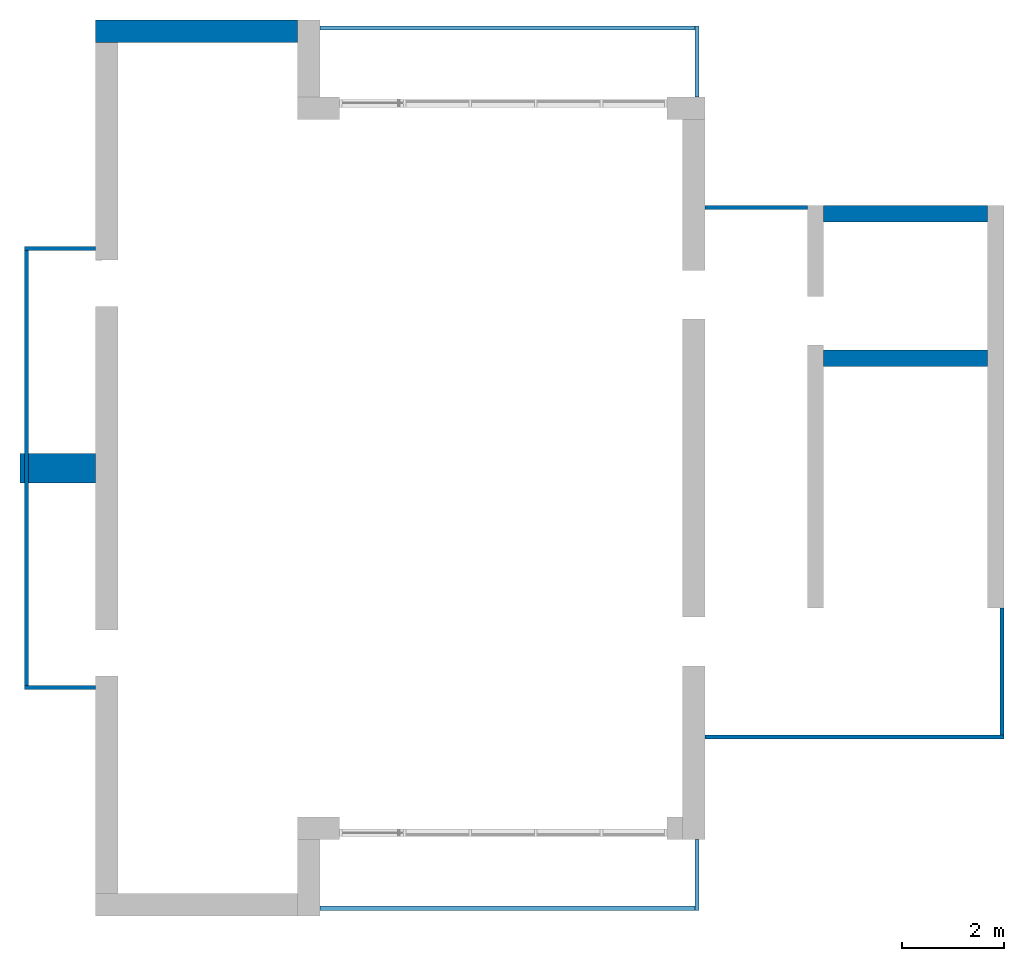
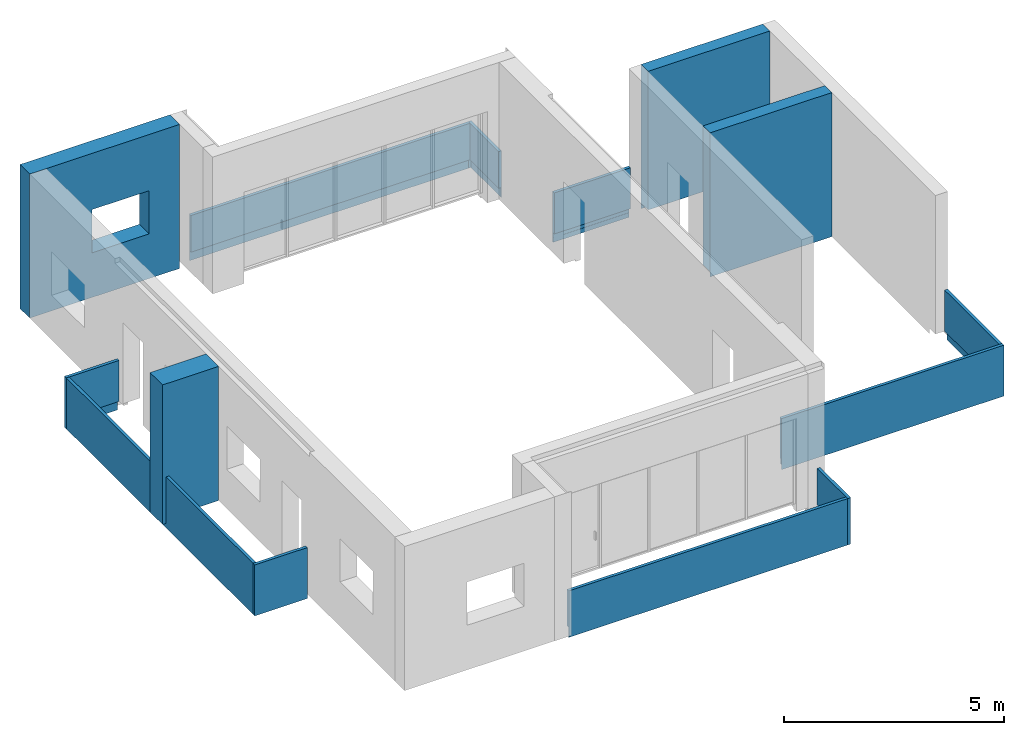
# One storey, part 2 of 4: 14 walls, 1 opening.
"""IFC2X3 building model written with IfcOpenShell, lengths in millimetres."""

from ifc_helpers import new_model, entity, si_unit, converted_unit, derived_unit, direction, frame, frame_2d, origin, place, context, subcontext, project, spatial, polyline, rectangle, extrude, clip, bounded_halfspace, faceted_brep, material, layer, layer_set, layer_usage, type_object, element, save


model = new_model("IFC2X3")

# Units and contexts
model_context = context("Model", 3, precision=0.01, world=origin(), true_north=direction((6.12303176911189e-17, 1.0)))
body_context = subcontext(model_context, "Body", "Model", "MODEL_VIEW")
ifc_project = project(units=[si_unit("LENGTHUNIT", "METRE", prefix="MILLI"), si_unit("AREAUNIT", "SQUARE_METRE"), si_unit("VOLUMEUNIT", "CUBIC_METRE"), converted_unit("PLANEANGLEUNIT", "DEGREE", entity("IfcRatioMeasure", 0.0174532925199433), si_unit("PLANEANGLEUNIT", "RADIAN"), dimensions=[0, 0, 0, 0, 0, 0, 0]), si_unit("MASSUNIT", "GRAM", prefix="KILO"), derived_unit("MASSDENSITYUNIT", [(si_unit("MASSUNIT", "GRAM", prefix="KILO"), 1), (si_unit("LENGTHUNIT", "METRE"), -3)]), si_unit("TIMEUNIT", "SECOND"), si_unit("FREQUENCYUNIT", "HERTZ"), si_unit("THERMODYNAMICTEMPERATUREUNIT", "DEGREE_CELSIUS"), derived_unit("THERMALTRANSMITTANCEUNIT", [(si_unit("MASSUNIT", "GRAM", prefix="KILO"), 1), (si_unit("THERMODYNAMICTEMPERATUREUNIT", "KELVIN"), -1), (si_unit("TIMEUNIT", "SECOND"), -3)]), derived_unit("VOLUMETRICFLOWRATEUNIT", [(si_unit("LENGTHUNIT", "METRE"), 3), (si_unit("TIMEUNIT", "SECOND"), -1)]), si_unit("ELECTRICCURRENTUNIT", "AMPERE"), si_unit("ELECTRICVOLTAGEUNIT", "VOLT"), si_unit("POWERUNIT", "WATT"), si_unit("FORCEUNIT", "NEWTON", prefix="KILO"), si_unit("ILLUMINANCEUNIT", "LUX"), si_unit("LUMINOUSFLUXUNIT", "LUMEN"), si_unit("LUMINOUSINTENSITYUNIT", "CANDELA"), derived_unit("USERDEFINED", [(si_unit("MASSUNIT", "GRAM", prefix="KILO"), -1), (si_unit("LENGTHUNIT", "METRE"), -2), (si_unit("TIMEUNIT", "SECOND"), 3), (si_unit("LUMINOUSFLUXUNIT", "LUMEN"), 1)]), derived_unit("LINEARVELOCITYUNIT", [(si_unit("LENGTHUNIT", "METRE"), 1), (si_unit("TIMEUNIT", "SECOND"), -1)]), si_unit("PRESSUREUNIT", "PASCAL"), derived_unit("USERDEFINED", [(si_unit("LENGTHUNIT", "METRE"), -2), (si_unit("MASSUNIT", "GRAM", prefix="KILO"), 1), (si_unit("TIMEUNIT", "SECOND"), -2)])], contexts=[model_context])

# Site, building, storey
site_placement = place(None, origin())
site = spatial("IfcSite", under=ifc_project, at=site_placement, CompositionType="ELEMENT")
building_placement = place(site_placement, origin())
building = spatial("IfcBuilding", under=site, at=building_placement, CompositionType="ELEMENT")
storey_placement = place(building_placement, frame((0.0, 0.0, 12000.0)))
storey = spatial("IfcBuildingStorey", under=building, at=storey_placement, Name="03 Level", CompositionType="ELEMENT", Elevation=12000.0)

# Wall, opening
ifc_material_1 = material(Name="03")
ifc_layer_1 = layer(ifc_material_1, 10.0)
ifc_material_2 = material()
ifc_layer_2 = layer(ifc_material_2, 120.0)
ifc_material_3 = material()
ifc_layer_3 = layer(ifc_material_3, 300.0)
ifc_layer_4 = layer(ifc_material_1, 10.0)
ifc_layer_set_1 = layer_set([ifc_layer_1, ifc_layer_2, ifc_layer_3, ifc_layer_4], Name="Basic Wall:00_fal+12 cm")
ifc_layer_usage_1 = layer_usage(ifc_layer_set_1, "AXIS2", "POSITIVE", -220.0)
wall_type_1 = type_object("IfcWallType", Name="Basic Wall:00_fal+12 cm", PredefinedType="STANDARD", material=ifc_layer_set_1)
wall_1_placement = place(storey_placement, frame((20983.4900708518, -60301.2395851399, -340.0), z_axis=(0.0, 0.0, 1.0), x_axis=(-1.0, 0.0, 0.0)))
wall_1 = element("IfcWallStandardCase", 1, at=wall_1_placement, inside=storey, type_object=wall_type_1, material=ifc_layer_usage_1, Name="Basic Wall:00_fal+12 cm", ObjectType="Basic Wall:00_fal+12 cm", context=body_context, shape_type="SweptSolid", body=[
    extrude(rectangle(XDim=3940.00000000004, YDim=440.000000000004, at=frame_2d((1970.00000000002, -1.08002495835535e-12), x_axis=(-1.0, 0.0))), origin(), (0.0, 0.0, 1.0), 4000.0),
])
opening_placement = place(wall_1_placement, frame((2300.0, 1304.0, 1240.0), z_axis=(0.0, 0.0, 1.0), x_axis=(-1.0, 0.0, 0.0)))
element("IfcOpeningElement", 2, at=opening_placement, cuts=wall_1, Name="Basic Wall:00_fal+12 cm", ObjectType="Opening", context=body_context, shape_type="SweptSolid", body=[
    extrude(rectangle(XDim=1200.0, YDim=1500.0, at=frame_2d((1.08002495835535e-12, 0.0), x_axis=(0.0, 1.0))), frame((750.0, 3048.0, 600.0), z_axis=(0.0, -1.0, 0.0), x_axis=(1.0, 0.0, 0.0)), (0.0, 0.0, 1.0), 3048.0),
])

# Walls
ifc_layer_5 = layer(ifc_material_1, 10.0)
ifc_layer_6 = layer(ifc_material_3, 300.0)
ifc_layer_7 = layer(ifc_material_1, 10.0)
ifc_layer_set_2 = layer_set([ifc_layer_5, ifc_layer_6, ifc_layer_7], Name="Basic Wall:00_fal 300 mm")
ifc_layer_usage_2 = layer_usage(ifc_layer_set_2, "AXIS2", "NEGATIVE", 160.0)
wall_type_2 = type_object("IfcWallType", Name="Basic Wall:00_fal 300 mm", PredefinedType="STANDARD", material=ifc_layer_set_2)
wall_2_placement = place(storey_placement, frame((31263.4900708518, -66685.8241905964, -340.0)))
element("IfcWallStandardCase", 3, at=wall_2_placement, inside=storey, type_object=wall_type_2, material=ifc_layer_usage_2, Name="Basic Wall:00_fal 300 mm", ObjectType="Basic Wall:00_fal 300 mm", context=body_context, shape_type="Clipping", body=[
    clip(clip(extrude(rectangle(XDim=3199.99999999998, YDim=319.999999999997, at=frame_2d((1599.99999999999, 1.406874616805e-12), x_axis=(-1.0, 0.0))), origin(), (0.0, 0.0, 1.0), 4000.0), bounded_halfspace(frame((3200.0, -150.0, 150.0), z_axis=(0.0, 0.0, 1.0), x_axis=(0.0, 1.0, 0.0)), True, frame((3200.0, -150.0, 150.0), z_axis=(0.0, 0.0, 1.0), x_axis=(0.0, 1.0, 0.0)), polyline([(0.0, 0.0), (310.0, 0.0), (310.0, 3200.0), (0.0, 3200.0), (0.0, 0.0)]))), bounded_halfspace(frame((0.0, -150.0, 150.0), z_axis=(0.0, -1.0, 0.0), x_axis=(0.0, 0.0, 1.0)), True, frame((0.0, -150.0, 150.0), z_axis=(0.0, -1.0, 0.0), x_axis=(0.0, 0.0, 1.0)), polyline([(0.0, 0.0), (-150.0, 0.0), (-150.0, -3200.0), (0.0, -3200.0), (0.0, 0.0)]))),
])
ifc_layer_usage_3 = layer_usage(ifc_layer_set_2, "AXIS2", "NEGATIVE", 160.0)
wall_3_placement = place(storey_placement, frame((31263.4900708518, -63865.8241905964, -340.0)))
element("IfcWallStandardCase", 4, at=wall_3_placement, inside=storey, type_object=wall_type_2, material=ifc_layer_usage_3, Name="Basic Wall:00_fal 300 mm", ObjectType="Basic Wall:00_fal 300 mm", context=body_context, shape_type="Clipping", body=[
    clip(clip(extrude(rectangle(XDim=3199.99999999998, YDim=319.999999999997, at=frame_2d((1599.99999999999, 0.0), x_axis=(-1.0, 0.0))), origin(), (0.0, 0.0, 1.0), 4000.0), bounded_halfspace(frame((0.0, 150.0, 150.0), z_axis=(0.0, 0.0, 1.0), x_axis=(0.0, 1.0, 0.0)), True, frame((0.0, 150.0, 150.0), z_axis=(0.0, 0.0, 1.0), x_axis=(0.0, 1.0, 0.0)), polyline([(0.0, 0.0), (-310.0, 0.0), (-310.0, -3200.0), (0.0, -3200.0), (0.0, 0.0)]))), bounded_halfspace(frame((3200.0, 150.0, 150.0), z_axis=(0.0, 1.0, 0.0), x_axis=(0.0, 0.0, 1.0)), True, frame((3200.0, 150.0, 150.0), z_axis=(0.0, 1.0, 0.0), x_axis=(0.0, 0.0, 1.0)), polyline([(0.0, 0.0), (-150.0, 0.0), (-150.0, -3200.0), (0.0, -3200.0), (0.0, 0.0)]))),
])
ifc_layer_8 = layer(ifc_material_1, 10.0)
ifc_material_4 = material(Name="06_ APP")
ifc_layer_9 = layer(ifc_material_4, 10.0)
ifc_layer_10 = layer(ifc_material_2, 120.0)
ifc_layer_11 = layer(ifc_material_3, 300.0)
ifc_material_5 = material()
ifc_layer_12 = layer(ifc_material_5, 120.0)
ifc_layer_13 = layer(ifc_material_1, 10.0)
ifc_layer_set_3 = layer_set([ifc_layer_8, ifc_layer_9, ifc_layer_10, ifc_layer_11, ifc_layer_12, ifc_layer_13], Name="Basic Wall:00_fal+2x12 cm")
ifc_layer_usage_4 = layer_usage(ifc_layer_set_3, "AXIS2", "NEGATIVE", 285.0)
wall_type_3 = type_object("IfcWallType", Name="Basic Wall:00_fal+2x12 cm", PredefinedType="STANDARD", material=ifc_layer_set_3)
wall_4_placement = place(storey_placement, frame((17043.4900708518, -68836.2395851399, -340.0), z_axis=(0.0, 0.0, 1.0), x_axis=(-1.0, 0.0, 0.0)))
element("IfcWallStandardCase", 5, at=wall_4_placement, inside=storey, type_object=wall_type_3, material=ifc_layer_usage_4, Name="Basic Wall:00_fal+2x12 cm", ObjectType="Basic Wall:00_fal+2x12 cm", context=body_context, shape_type="Clipping", body=[
    clip(clip(clip(extrude(rectangle(XDim=1474.99999999999, YDim=569.999999999992, at=frame_2d((737.499999999995, 1.70530256582424e-13), x_axis=(-1.0, 0.0))), origin(), (0.0, 0.0, 1.0), 3875.0), bounded_halfspace(frame((0.0, -285.0, 3875.0), z_axis=(0.0, 0.0, -1.0), x_axis=(-1.0, 0.0, 0.0)), True, frame((0.0, -285.0, 3875.0), z_axis=(0.0, 0.0, -1.0), x_axis=(-1.0, 0.0, 0.0)), polyline([(0.0, 0.0), (0.0, 570.0), (-1475.0, 570.0), (-1475.0, 0.0), (0.0, 0.0)]))), bounded_halfspace(frame((1370.0, 285.0, 150.0)), True, frame((1370.0, 285.0, 150.0)), polyline([(0.0, 0.0), (-1370.0, 0.0), (-1370.0, -570.0), (0.0, -570.0), (0.0, 0.0)]))), bounded_halfspace(frame((1370.0, -285.0, 150.0), z_axis=(1.0, 0.0, 0.0), x_axis=(0.0, 0.0, 1.0)), True, frame((1370.0, -285.0, 150.0), z_axis=(1.0, 0.0, 0.0), x_axis=(0.0, 0.0, 1.0)), polyline([(0.0, 0.0), (-150.0, 0.0), (-150.0, -570.0), (0.0, -570.0), (0.0, 0.0)]))),
])
ifc_material_6 = material(Name="03")
ifc_layer_14 = layer(ifc_material_6, 15.0)
ifc_material_7 = material(Name="02_C40/55")
ifc_layer_15 = layer(ifc_material_7, 50.0)
ifc_layer_16 = layer(ifc_material_6, 15.0)
ifc_layer_set_4 = layer_set([ifc_layer_14, ifc_layer_15, ifc_layer_16], Name="Basic Wall:00_fal")
ifc_layer_usage_5 = layer_usage(ifc_layer_set_4, "AXIS2", "NEGATIVE", 40.0)
wall_type_4 = type_object("IfcWallType", Name="Basic Wall:00_fal", PredefinedType="STANDARD", material=ifc_layer_set_4)
wall_5_placement = place(storey_placement, frame((28788.4900708518, -76081.2395851399, -465.0), z_axis=(0.0, 0.0, 1.0), x_axis=(0.0, -1.0, 0.0)))
element("IfcWallStandardCase", 6, at=wall_5_placement, inside=storey, type_object=wall_type_4, material=ifc_layer_usage_5, Name="Basic Wall:00_fal", ObjectType="Basic Wall:00_fal", context=body_context, shape_type="Clipping", body=[
    clip(clip(clip(extrude(rectangle(XDim=1384.99999999999, YDim=79.9999999999991, at=frame_2d((692.499999999994, 0.0), x_axis=(-1.0, 0.0))), origin(), (0.0, 0.0, 1.0), 1290.0), bounded_halfspace(frame((1370.0, 25.0, 275.0), z_axis=(0.0, 1.0, 0.0), x_axis=(0.0, 0.0, 1.0)), True, frame((1370.0, 25.0, 275.0), z_axis=(0.0, 1.0, 0.0), x_axis=(0.0, 0.0, 1.0)), polyline([(0.0, 0.0), (-150.0, 0.0), (-275.0, 0.0), (-275.0, -1370.0), (0.0, -1370.0), (0.0, 0.0)]))), bounded_halfspace(frame((1370.0, 25.0, 275.0), z_axis=(1.0, 0.0, 0.0), x_axis=(0.0, 0.0, 1.0)), True, frame((1370.0, 25.0, 275.0), z_axis=(1.0, 0.0, 0.0), x_axis=(0.0, 0.0, 1.0)), polyline([(0.0, 0.0), (0.0, 65.0), (-275.0, 65.0), (-275.0, 0.0), (-150.0, 0.0), (0.0, 0.0)]))), bounded_halfspace(frame((0.0, 25.0, 275.0), z_axis=(0.0, 0.0, 1.0), x_axis=(0.0, -1.0, 0.0)), True, frame((0.0, 25.0, 275.0), z_axis=(0.0, 0.0, 1.0), x_axis=(0.0, -1.0, 0.0)), polyline([(0.0, 0.0), (65.0, 0.0), (65.0, 1305.0), (65.0, 1370.0), (0.0, 1370.0), (0.0, 0.0)]))),
])
ifc_layer_usage_6 = layer_usage(ifc_layer_set_4, "AXIS2", "NEGATIVE", 40.0)
wall_6_placement = place(storey_placement, frame((28748.4900708518, -77426.2395851399, -465.0), z_axis=(0.0, 0.0, 1.0), x_axis=(-1.0, 0.0, 0.0)))
element("IfcWallStandardCase", 7, at=wall_6_placement, inside=storey, type_object=wall_type_4, material=ifc_layer_usage_6, Name="Basic Wall:00_fal", ObjectType="Basic Wall:00_fal", context=body_context, shape_type="Clipping", body=[
    clip(clip(extrude(rectangle(XDim=7325.0, YDim=79.9999999999991, at=frame_2d((3662.5, 0.0), x_axis=(-1.0, 0.0))), origin(), (0.0, 0.0, 1.0), 1290.0), bounded_halfspace(frame((0.0, 25.0, 275.0)), True, frame((0.0, 25.0, 275.0)), polyline([(0.0, 0.0), (0.0, -65.0), (7325.0, -65.0), (7325.0, 0.0), (0.0, 0.0)]))), bounded_halfspace(frame((7325.0, 25.0, 275.0), z_axis=(0.0, 1.0, 0.0), x_axis=(0.0, 0.0, 1.0)), True, frame((7325.0, 25.0, 275.0), z_axis=(0.0, 1.0, 0.0), x_axis=(0.0, 0.0, 1.0)), polyline([(0.0, 0.0), (-275.0, 0.0), (-275.0, -7325.0), (-150.0, -7325.0), (0.0, -7325.0), (0.0, 0.0)]))),
])
ifc_layer_usage_7 = layer_usage(ifc_layer_set_4, "AXIS2", "NEGATIVE", 40.0)
wall_7_placement = place(storey_placement, frame((17043.4900708518, -73116.2395851399, -465.0), z_axis=(0.0, 0.0, 1.0), x_axis=(-1.0, 0.0, 0.0)))
element("IfcWallStandardCase", 8, at=wall_7_placement, inside=storey, type_object=wall_type_4, material=ifc_layer_usage_7, Name="Basic Wall:00_fal", ObjectType="Basic Wall:00_fal", context=body_context, shape_type="Clipping", body=[
    clip(clip(clip(extrude(rectangle(XDim=1385.00000000002, YDim=79.9999999999991, at=frame_2d((692.500000000011, 4.9737991503207e-14), x_axis=(-1.0, 0.0))), origin(), (0.0, 0.0, 1.0), 1415.0), bounded_halfspace(frame((1370.0, 25.0, 0.0), z_axis=(1.0, 0.0, 0.0), x_axis=(0.0, 0.0, 1.0)), True, frame((1370.0, 25.0, 0.0), z_axis=(1.0, 0.0, 0.0), x_axis=(0.0, 0.0, 1.0)), polyline([(0.0, 0.0), (125.0, 0.0), (275.0, 0.0), (275.0, 65.0), (0.0, 65.0), (0.0, 0.0)]))), bounded_halfspace(frame((1370.0, 25.0, 0.0), z_axis=(0.0, 1.0, 0.0), x_axis=(0.0, 0.0, 1.0)), True, frame((1370.0, 25.0, 0.0), z_axis=(0.0, 1.0, 0.0), x_axis=(0.0, 0.0, 1.0)), polyline([(0.0, 0.0), (0.0, -1370.0), (125.0, -1370.0), (275.0, -1370.0), (275.0, 0.0), (125.0, 0.0), (0.0, 0.0)]))), bounded_halfspace(frame((1370.0, 25.0, 275.0)), True, frame((1370.0, 25.0, 275.0)), polyline([(0.0, 0.0), (-1370.0, 0.0), (-1370.0, -65.0), (-65.0, -65.0), (0.0, -65.0), (0.0, 0.0)]))),
])
ifc_layer_usage_8 = layer_usage(ifc_layer_set_4, "AXIS2", "NEGATIVE", 40.0)
wall_8_placement = place(storey_placement, frame((15698.4900708517, -73076.2395851399, -465.0), z_axis=(0.0, 0.0, 1.0), x_axis=(0.0, 1.0, 0.0)))
element("IfcWallStandardCase", 9, at=wall_8_placement, inside=storey, type_object=wall_type_4, material=ifc_layer_usage_8, Name="Basic Wall:00_fal", ObjectType="Basic Wall:00_fal", context=body_context, shape_type="Clipping", body=[
    clip(clip(extrude(rectangle(XDim=8489.99999999998, YDim=79.9999999999991, at=frame_2d((4244.99999999999, 3.48165940522449e-13), x_axis=(-1.0, 0.0))), origin(), (0.0, 0.0, 1.0), 1415.0), bounded_halfspace(frame((0.0, 25.0, 0.0), z_axis=(0.0, 1.0, 0.0), x_axis=(0.0, 0.0, 1.0)), True, frame((0.0, 25.0, 0.0), z_axis=(0.0, 1.0, 0.0), x_axis=(0.0, 0.0, 1.0)), polyline([(0.0, 0.0), (125.0, 0.0), (275.0, 0.0), (275.0, 8490.0), (125.0, 8490.0), (0.0, 8490.0), (0.0, 0.0)]))), bounded_halfspace(frame((0.0, 25.0, 275.0), z_axis=(0.0, 0.0, 1.0), x_axis=(0.0, 1.0, 0.0)), True, frame((0.0, 25.0, 275.0), z_axis=(0.0, 0.0, 1.0), x_axis=(0.0, 1.0, 0.0)), polyline([(0.0, 0.0), (-65.0, 0.0), (-65.0, -8490.0), (0.0, -8490.0), (0.0, 0.0)]))),
])
ifc_layer_usage_9 = layer_usage(ifc_layer_set_4, "AXIS2", "POSITIVE", -40.0)
wall_9_placement = place(storey_placement, frame((17043.4900708518, -64546.2395851399, -465.0), z_axis=(0.0, 0.0, 1.0), x_axis=(-1.0, 0.0, 0.0)))
element("IfcWallStandardCase", 10, at=wall_9_placement, inside=storey, type_object=wall_type_4, material=ifc_layer_usage_9, Name="Basic Wall:00_fal", ObjectType="Basic Wall:00_fal", context=body_context, shape_type="Clipping", body=[
    clip(clip(clip(extrude(rectangle(XDim=1385.00000000003, YDim=79.9999999999991, at=frame_2d((692.500000000013, -1.73372427525464e-12), x_axis=(-1.0, 0.0))), origin(), (0.0, 0.0, 1.0), 1415.0), bounded_halfspace(frame((1370.0, -25.0, 275.0), z_axis=(1.0, 0.0, 0.0), x_axis=(0.0, 0.0, 1.0)), True, frame((1370.0, -25.0, 275.0), z_axis=(1.0, 0.0, 0.0), x_axis=(0.0, 0.0, 1.0)), polyline([(0.0, 0.0), (-150.0, 0.0), (-275.0, 0.0), (-275.0, -65.0), (0.0, -65.0), (0.0, 0.0)]))), bounded_halfspace(frame((1370.0, -25.0, 275.0), z_axis=(0.0, -1.0, 0.0), x_axis=(0.0, 0.0, 1.0)), True, frame((1370.0, -25.0, 275.0), z_axis=(0.0, -1.0, 0.0), x_axis=(0.0, 0.0, 1.0)), polyline([(0.0, 0.0), (0.0, 1370.0), (-150.0, 1370.0), (-275.0, 1370.0), (-275.0, 0.0), (-150.0, 0.0), (0.0, 0.0)]))), bounded_halfspace(frame((1370.0, 40.0, 275.0)), True, frame((1370.0, 40.0, 275.0)), polyline([(0.0, 0.0), (-65.0, 0.0), (-1370.0, 0.0), (-1370.0, -65.0), (0.0, -65.0), (0.0, 0.0)]))),
])
ifc_layer_usage_10 = layer_usage(ifc_layer_set_4, "AXIS2", "POSITIVE", -40.0)
wall_10_placement = place(storey_placement, frame((28788.4900708518, -61581.2395851401, -465.0), z_axis=(0.0, 0.0, 1.0), x_axis=(0.0, 1.0, 0.0)))
element("IfcWallStandardCase", 11, at=wall_10_placement, inside=storey, type_object=wall_type_4, material=ifc_layer_usage_10, Name="Basic Wall:00_fal", ObjectType="Basic Wall:00_fal", context=body_context, shape_type="Clipping", body=[
    clip(clip(clip(extrude(rectangle(XDim=1385.00000000007, YDim=79.9999999999991, at=frame_2d((692.500000000033, -1.4210854715202e-13), x_axis=(-1.0, 0.0))), origin(), (0.0, 0.0, 1.0), 1290.0), bounded_halfspace(frame((1370.0, -25.0, 275.0), z_axis=(1.0, 0.0, 0.0), x_axis=(0.0, 0.0, 1.0)), True, frame((1370.0, -25.0, 275.0), z_axis=(1.0, 0.0, 0.0), x_axis=(0.0, 0.0, 1.0)), polyline([(0.0, 0.0), (-150.0, 0.0), (-275.0, 0.0), (-275.0, -65.0), (0.0, -65.0), (0.0, 0.0)]))), bounded_halfspace(frame((1370.0, -25.0, 275.0), z_axis=(0.0, -1.0, 0.0), x_axis=(0.0, 0.0, 1.0)), True, frame((1370.0, -25.0, 275.0), z_axis=(0.0, -1.0, 0.0), x_axis=(0.0, 0.0, 1.0)), polyline([(0.0, 0.0), (0.0, 1370.0), (-150.0, 1370.0), (-275.0, 1370.0), (-275.0, 0.0), (-150.0, 0.0), (0.0, 0.0)]))), bounded_halfspace(frame((1370.0, 40.0, 275.0), z_axis=(0.0, 0.0, 1.0), x_axis=(0.0, 1.0, 0.0)), True, frame((1370.0, 40.0, 275.0), z_axis=(0.0, 0.0, 1.0), x_axis=(0.0, 1.0, 0.0)), polyline([(0.0, 0.0), (0.0, 65.0), (0.0, 1370.0), (-65.0, 1370.0), (-65.0, 0.0), (0.0, 0.0)]))),
])
ifc_layer_usage_11 = layer_usage(ifc_layer_set_4, "AXIS2", "POSITIVE", -40.0)
wall_11_placement = place(storey_placement, frame((28748.4900708518, -60236.23958514, -465.0), z_axis=(0.0, 0.0, 1.0), x_axis=(-1.0, 0.0, 0.0)))
element("IfcWallStandardCase", 12, at=wall_11_placement, inside=storey, type_object=wall_type_4, material=ifc_layer_usage_11, Name="Basic Wall:00_fal", ObjectType="Basic Wall:00_fal", context=body_context, shape_type="Clipping", body=[
    clip(clip(extrude(rectangle(XDim=7325.0, YDim=79.9999999999991, at=frame_2d((3662.5, 4.9382720135327e-13), x_axis=(-1.0, 0.0))), origin(), (0.0, 0.0, 1.0), 1290.0), bounded_halfspace(frame((7325.0, -25.0, 275.0)), True, frame((7325.0, -25.0, 275.0)), polyline([(0.0, 0.0), (0.0, 65.0), (-7325.0, 65.0), (-7325.0, 0.0), (0.0, 0.0)]))), bounded_halfspace(frame((0.0, -25.0, 275.0), z_axis=(0.0, -1.0, 0.0), x_axis=(0.0, 0.0, 1.0)), True, frame((0.0, -25.0, 275.0), z_axis=(0.0, -1.0, 0.0), x_axis=(0.0, 0.0, 1.0)), polyline([(0.0, 0.0), (-275.0, 0.0), (-275.0, -7325.0), (0.0, -7325.0), (0.0, 0.0)]))),
])
ifc_layer_usage_12 = layer_usage(ifc_layer_set_4, "AXIS2", "NEGATIVE", 40.0)
wall_12_placement = place(storey_placement, frame((30943.4900708518, -63745.8241905964, -465.0), z_axis=(0.0, 0.0, 1.0), x_axis=(-1.0, 0.0, 0.0)))
element("IfcWallStandardCase", 13, at=wall_12_placement, inside=storey, type_object=wall_type_4, material=ifc_layer_usage_12, Name="Basic Wall:00_fal", ObjectType="Basic Wall:00_fal", context=body_context, shape_type="Clipping", body=[
    clip(clip(extrude(rectangle(XDim=2000.00000000001, YDim=79.9999999999991, at=frame_2d((1000.00000000001, 0.0), x_axis=(-1.0, 0.0))), origin(), (0.0, 0.0, 1.0), 1415.0), bounded_halfspace(frame((0.0, -30.0, 275.0), z_axis=(0.0, -1.0, 0.0), x_axis=(0.0, 0.0, 1.0)), True, frame((0.0, -30.0, 275.0), z_axis=(0.0, -1.0, 0.0), x_axis=(0.0, 0.0, 1.0)), polyline([(0.0, 0.0), (-150.0, 0.0), (-150.0, -2000.0), (0.0, -2000.0), (0.0, 0.0)]))), bounded_halfspace(frame((2000.0, -25.0, 0.0), z_axis=(0.0, -1.0, 0.0), x_axis=(0.0, 0.0, 1.0)), True, frame((2000.0, -25.0, 0.0), z_axis=(0.0, -1.0, 0.0), x_axis=(0.0, 0.0, 1.0)), polyline([(0.0, 0.0), (125.0, 0.0), (125.0, 2000.0), (0.0, 2000.0), (0.0, 0.0)]))),
])
wall_13_placement = place(storey_placement, frame((34783.4900708518, -74085.8241905963, -465.0), z_axis=(0.0, 0.0, 1.0), x_axis=(-1.0, 0.0, 0.0)))
element("IfcWall", 14, at=wall_13_placement, inside=storey, type_object=wall_type_4, Name="Basic Wall:00_fal", ObjectType="Basic Wall:00_fal", context=body_context, shape_type="Brep", body=[
    faceted_brep([(5840.0, -40.0, 1415.0), (80.0, -40.0, 1415.0), (0.0, -40.0, 1415.0), (0.0, -40.0, 0.0), (10.0, -40.0, 0.0), (10.0, -40.0, 275.0), (80.0, -40.0, 275.0), (5840.0, -40.0, 275.0), (5840.0, -40.0, 465.0), (5840.0, 40.0, 0.0), (0.0, 40.0, 0.0), (0.0, 40.0, 1415.0), (5840.0, 40.0, 1415.0), (5840.0, 30.0, 0.0), (10.0, 30.0, 0.0), (5840.0, -25.0, 275.0), (5840.0, -25.0, 125.0), (5840.0, 30.0, 125.0), (10.0, -25.0, 275.0), (10.0, -25.0, 125.0), (10.0, 30.0, 125.0)], [[[0, 1, 2, 3, 4, 5, 6, 7, 8]], [[9, 10, 11, 12]], [[10, 9, 13, 14, 4, 3]], [[9, 12, 0, 8, 7, 15, 16, 17, 13]], [[2, 1, 0, 12, 11]], [[3, 2, 11, 10]], [[5, 18, 15, 7, 6]], [[19, 18, 5, 4, 14, 20]], [[18, 19, 16, 15]], [[19, 20, 17, 16]], [[20, 14, 13, 17]]]),
])
ifc_layer_usage_13 = layer_usage(ifc_layer_set_4, "AXIS2", "NEGATIVE", 40.0)
wall_14_placement = place(storey_placement, frame((34743.4900708518, -71560.8241905963, -465.0), z_axis=(0.0, 0.0, 1.0), x_axis=(0.0, -1.0, 0.0)))
element("IfcWallStandardCase", 15, at=wall_14_placement, inside=storey, type_object=wall_type_4, material=ifc_layer_usage_13, Name="Basic Wall:00_fal", ObjectType="Basic Wall:00_fal", context=body_context, shape_type="Clipping", body=[
    clip(clip(extrude(rectangle(XDim=2484.99999999999, YDim=79.9999999999991, at=frame_2d((1242.49999999999, 0.0), x_axis=(-1.0, 0.0))), origin(), (0.0, 0.0, 1.0), 1415.0), bounded_halfspace(frame((2485.0, -40.0, 275.0), z_axis=(0.0, 0.0, 1.0), x_axis=(-1.0, 0.0, 0.0)), True, frame((2485.0, -40.0, 275.0), z_axis=(0.0, 0.0, 1.0), x_axis=(-1.0, 0.0, 0.0)), polyline([(0.0, 0.0), (0.0, -70.0), (2485.0, -70.0), (2485.0, 0.0), (0.0, 0.0)]))), bounded_halfspace(frame((2485.0, 30.0, 275.0), z_axis=(0.0, 1.0, 0.0), x_axis=(0.0, 0.0, 1.0)), True, frame((2485.0, 30.0, 275.0), z_axis=(0.0, 1.0, 0.0), x_axis=(0.0, 0.0, 1.0)), polyline([(0.0, 0.0), (-275.0, 0.0), (-275.0, -2485.0), (-150.0, -2485.0), (0.0, -2485.0), (0.0, 0.0)]))),
])

save(model, "model.ifc")
